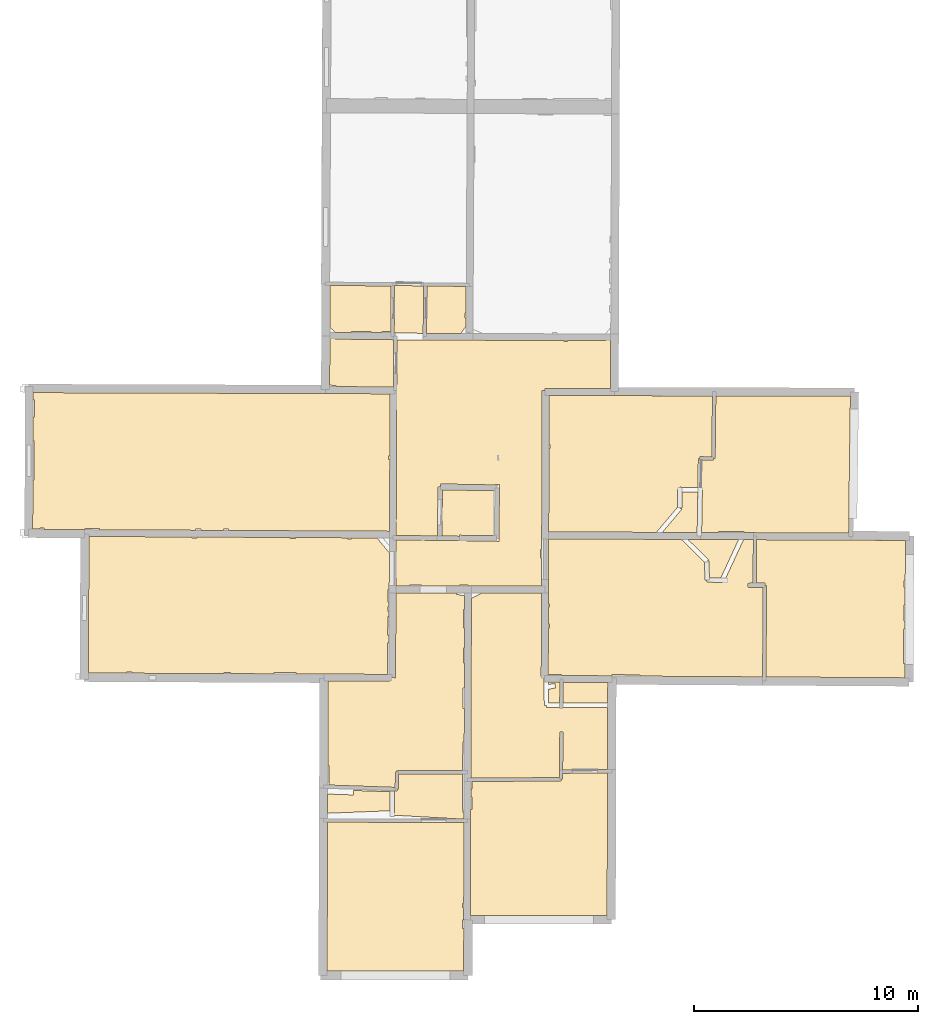
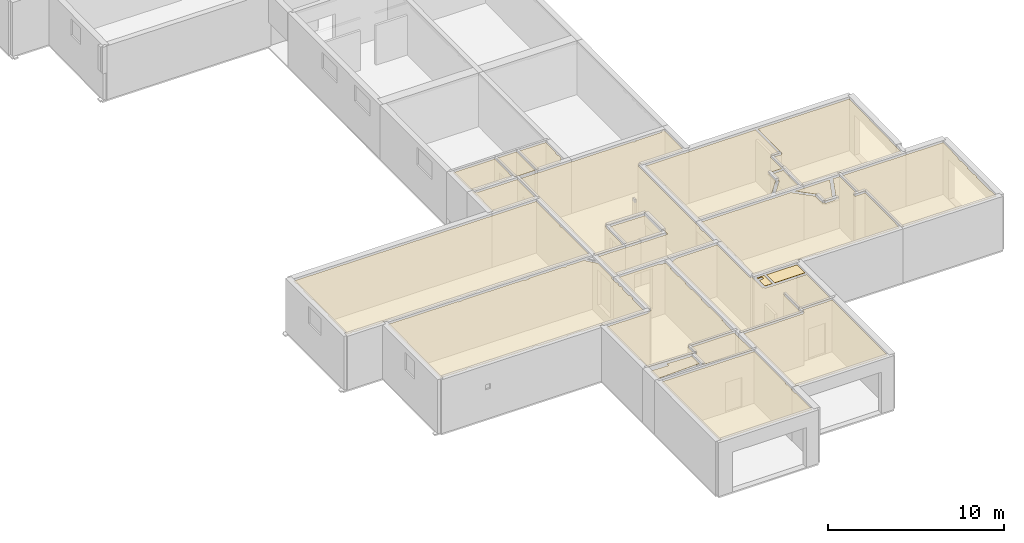
# One storey, part 8 of 12: 22 coverings.
"""IFC2X3 building model written with IfcOpenShell, lengths in metres."""

from ifc_helpers import new_model, entity, si_unit, converted_unit, derived_unit, direction, frame, origin, origin_with_axes, place, context, subcontext, project, spatial, polyline, outline, extrude, material, layer, layer_set, layer_usage, type_object, element, save


model = new_model("IFC2X3")

# Units and contexts
model_context = context("Model", 3, precision=1e-05, world=origin(), true_north=direction((0.0, 1.0)))
body_context = subcontext(model_context, "Body", "Model", "MODEL_VIEW")
ifc_project = project(units=[si_unit("LENGTHUNIT", "METRE"), si_unit("AREAUNIT", "SQUARE_METRE"), si_unit("VOLUMEUNIT", "CUBIC_METRE"), converted_unit("PLANEANGLEUNIT", "DEGREE", entity("IfcRatioMeasure", 0.0174532925199433), si_unit("PLANEANGLEUNIT", "RADIAN"), dimensions=[0, 0, 0, 0, 0, 0, 0]), si_unit("MASSUNIT", "GRAM", prefix="KILO"), derived_unit("MASSDENSITYUNIT", [(si_unit("MASSUNIT", "GRAM", prefix="KILO"), 1), (si_unit("LENGTHUNIT", "METRE"), -3)]), derived_unit("MOMENTOFINERTIAUNIT", [(si_unit("LENGTHUNIT", "METRE"), 4)]), si_unit("TIMEUNIT", "SECOND"), si_unit("FREQUENCYUNIT", "HERTZ"), si_unit("THERMODYNAMICTEMPERATUREUNIT", "DEGREE_CELSIUS"), derived_unit("THERMALTRANSMITTANCEUNIT", [(si_unit("MASSUNIT", "GRAM", prefix="KILO"), 1), (si_unit("THERMODYNAMICTEMPERATUREUNIT", "KELVIN"), -1), (si_unit("TIMEUNIT", "SECOND"), -3)]), derived_unit("VOLUMETRICFLOWRATEUNIT", [(si_unit("LENGTHUNIT", "METRE"), 3), (si_unit("TIMEUNIT", "SECOND"), -1)]), si_unit("ELECTRICCURRENTUNIT", "AMPERE"), si_unit("ELECTRICVOLTAGEUNIT", "VOLT"), si_unit("POWERUNIT", "WATT"), si_unit("FORCEUNIT", "NEWTON", prefix="KILO"), si_unit("ILLUMINANCEUNIT", "LUX"), si_unit("LUMINOUSFLUXUNIT", "LUMEN"), si_unit("LUMINOUSINTENSITYUNIT", "CANDELA"), derived_unit("USERDEFINED", [(si_unit("MASSUNIT", "GRAM", prefix="KILO"), -1), (si_unit("LENGTHUNIT", "METRE"), -2), (si_unit("TIMEUNIT", "SECOND"), 3), (si_unit("LUMINOUSFLUXUNIT", "LUMEN"), 1)]), derived_unit("LINEARVELOCITYUNIT", [(si_unit("LENGTHUNIT", "METRE"), 1), (si_unit("TIMEUNIT", "SECOND"), -1)]), si_unit("PRESSUREUNIT", "PASCAL"), derived_unit("USERDEFINED", [(si_unit("LENGTHUNIT", "METRE"), -2), (si_unit("MASSUNIT", "GRAM", prefix="KILO"), 1), (si_unit("TIMEUNIT", "SECOND"), -2)]), derived_unit("LINEARFORCEUNIT", [(si_unit("MASSUNIT", "GRAM", prefix="KILO"), 1), (si_unit("LENGTHUNIT", "METRE"), 1), (si_unit("TIMEUNIT", "SECOND"), -2), (si_unit("LENGTHUNIT", "METRE"), -1)]), derived_unit("PLANARFORCEUNIT", [(si_unit("MASSUNIT", "GRAM", prefix="KILO"), 1), (si_unit("LENGTHUNIT", "METRE"), 1), (si_unit("TIMEUNIT", "SECOND"), -2), (si_unit("LENGTHUNIT", "METRE"), -2)])], contexts=[model_context])

# Site, building, storey
placement = place(None, origin())
site = spatial("IfcSite", under=ifc_project, at=placement, CompositionType="ELEMENT")
building = spatial("IfcBuilding", under=site, at=placement, CompositionType="ELEMENT")
storey_placement = place(placement, frame((0.0, 0.0, -1.46125340461731)))
storey = spatial("IfcBuildingStorey", under=building, at=storey_placement, Name="Level 1", CompositionType="ELEMENT", Elevation=-1.46125340461731)

# Coverings
ifc_material = material(Name="Covering default")
ifc_layer_1 = layer(ifc_material, 0.02)
ifc_layer_set_1 = layer_set([ifc_layer_1], Name="Covering : 20mm")
ifc_layer_usage_1 = layer_usage(ifc_layer_set_1, "AXIS3", "POSITIVE", 0.0)
covering_type_1 = type_object("IfcCoveringType", Name="Covering : 20mm", PredefinedType="CEILING")
covering_1_placement = place(placement, frame((0.0, 0.0, 2.11485385894775)))
element("IfcCovering", 1, at=covering_1_placement, inside=storey, type_object=covering_type_1, material=ifc_layer_usage_1, Name="Covering : 20mm", ObjectType="Covering : 20mm", PredefinedType="CEILING", context=body_context, shape_type="SweptSolid", body=[
    extrude(outline(polyline([(-0.0963687896728516, 6.62952041625977), (5.98122024536133, 6.60954189300537), (5.97014427185059, 2.99506211280823), (5.91123962402344, 2.99501037597656), (5.9113883972168, 2.82501220703125), (5.96962356567383, 2.82506346702576), (5.96794891357422, 2.27837562561035), (6.10456275939941, 2.27795696258545), (5.9218692779541, 2.27779603004456), (5.92221450805664, 1.88502502441406), (5.97488975524902, 1.88507151603699), (5.96163558959961, -0.0119584202766418), (-0.121143341064453, -0.0165714919567108), (-0.0963687896728516, 6.62952041625977)])), origin_with_axes(), (0.0, 0.0, 1.0), 0.02),
])
ifc_layer_2 = layer(ifc_material, 0.02)
ifc_layer_set_2 = layer_set([ifc_layer_2], Name="Covering : 20mm")
ifc_layer_usage_2 = layer_usage(ifc_layer_set_2, "AXIS3", "POSITIVE", 0.0)
covering_type_2 = type_object("IfcCoveringType", Name="Covering : 20mm", PredefinedType="CEILING")
covering_2_placement = place(placement, frame((0.0, 0.0, 2.11485385894775)))
element("IfcCovering", 2, at=covering_2_placement, inside=storey, type_object=covering_type_2, material=ifc_layer_usage_2, Name="Covering : 20mm", ObjectType="Covering : 20mm", PredefinedType="CEILING", context=body_context, shape_type="SweptSolid", body=[
    extrude(outline(polyline([(6.28301620483398, 7.19533681869507), (6.33754920959473, 7.19538497924805), (6.33706665039062, 7.7453875541687), (6.28470230102539, 7.74534177780151), (6.28584098815918, 8.11738300323486), (6.33674049377441, 8.11539268493652), (6.34932899475098, 8.4371976852417), (10.309154510498, 8.46616649627686), (10.3086071014404, 8.54116344451904), (10.378604888916, 8.54075717926025), (10.3801307678223, 8.80403232574463), (12.3781356811523, 8.82392311096191), (12.3606109619141, 2.4650502204895), (6.26851463317871, 2.46296834945679), (6.28301620483398, 7.19533681869507)])), origin_with_axes(), (0.0, 0.0, 1.0), 0.02),
])
ifc_layer_3 = layer(ifc_material, 0.02)
ifc_layer_set_3 = layer_set([ifc_layer_3], Name="Covering : 20mm")
ifc_layer_usage_3 = layer_usage(ifc_layer_set_3, "AXIS3", "POSITIVE", 0.0)
covering_type_3 = type_object("IfcCoveringType", Name="Covering : 20mm", PredefinedType="CEILING")
covering_3_placement = place(placement, frame((0.0, 0.0, 2.11485385894775)))
element("IfcCovering", 3, at=covering_3_placement, inside=storey, type_object=covering_type_3, material=ifc_layer_usage_3, Name="Covering : 20mm", ObjectType="Covering : 20mm", PredefinedType="CEILING", context=body_context, shape_type="SweptSolid", body=[
    extrude(outline(polyline([(2.78989410400391, 6.93865871429443), (2.7858715057373, 7.03857851028442), (2.88587188720703, 7.03893566131592), (2.88233757019043, 8.02890682220459), (2.9877758026123, 8.02519226074219), (2.99041557312012, 8.10014343261719), (3.0654125213623, 8.09936714172363), (3.07246589660645, 8.7804651260376), (5.91583442687988, 8.77868938446045), (5.92767333984375, 7.05502700805664), (5.98258590698242, 7.05540418624878), (5.98167991638184, 6.75954103469849), (2.78989410400391, 6.93865871429443)])), origin_with_axes(), (0.0, 0.0, 1.0), 0.02),
])
ifc_layer_4 = layer(ifc_material, 0.02)
ifc_layer_set_4 = layer_set([ifc_layer_4], Name="Covering : 20mm")
ifc_layer_usage_4 = layer_usage(ifc_layer_set_4, "AXIS3", "POSITIVE", 0.0)
covering_type_4 = type_object("IfcCoveringType", Name="Covering : 20mm", PredefinedType="CEILING")
covering_4_placement = place(placement, frame((0.0, 0.0, 2.11485385894775)))
element("IfcCovering", 4, at=covering_4_placement, inside=storey, type_object=covering_type_4, material=ifc_layer_usage_4, Name="Covering : 20mm", ObjectType="Covering : 20mm", PredefinedType="CEILING", context=body_context, shape_type="SweptSolid", body=[
    extrude(outline(polyline([(-0.0916996002197266, 7.88211870193481), (1.05964374542236, 7.84087991714478), (1.06680297851562, 8.04075241088867), (2.68249702453613, 7.98376989364624), (2.6855297088623, 7.13461971282959), (-0.0949029922485352, 7.02269601821899), (-0.0916996002197266, 7.88211870193481)])), origin_with_axes(), (0.0, 0.0, 1.0), 0.02),
])
ifc_layer_5 = layer(ifc_material, 0.02)
ifc_layer_set_5 = layer_set([ifc_layer_5], Name="Covering : 20mm")
ifc_layer_usage_5 = layer_usage(ifc_layer_set_5, "AXIS3", "POSITIVE", 0.0)
covering_type_5 = type_object("IfcCoveringType", Name="Covering : 20mm", PredefinedType="CEILING")
covering_5_placement = place(placement, frame((0.0, 0.0, 2.11485385894775)))
element("IfcCovering", 5, at=covering_5_placement, inside=storey, type_object=covering_type_5, material=ifc_layer_usage_5, Name="Covering : 20mm", ObjectType="Covering : 20mm", PredefinedType="CEILING", context=body_context, shape_type="SweptSolid", body=[
    extrude(outline(polyline([(-0.0728960037231445, 12.9266767501831), (2.68170928955078, 12.9141788482666), (2.6823902130127, 13.0641679763794), (2.93192863464355, 13.0630531311035), (2.94876480102539, 16.8329925537109), (2.79961395263672, 16.8336582183838), (5.65909576416016, 16.8365707397461), (5.64912033081055, 16.7847843170166), (6.01218414306641, 16.7148475646973), (6.01031494140625, 16.1044960021973), (5.95971870422363, 16.1050605773926), (5.95044708251953, 15.2750511169434), (6.00777053833008, 15.2744112014771), (6.00507545471191, 14.3950977325439), (5.95122146606445, 14.3950500488281), (5.95181846618652, 13.7150497436523), (6.00299263000488, 13.7150945663452), (5.99959182739258, 12.605094909668), (5.94279289245605, 12.6050453186035), (5.94360160827637, 11.6850471496582), (5.99677276611328, 11.6850938796997), (5.99223327636719, 10.2041473388672), (5.93490219116211, 10.2050361633301), (5.91510200500488, 8.92868995666504), (2.9982852935791, 8.93051147460938), (2.99823760986328, 8.85550975799561), (2.92324256896973, 8.85628604888916), (2.91621589660645, 8.17780685424805), (-0.0334091186523438, 8.2817268371582), (-0.0341815948486328, 9.1597900390625), (-0.0869369506835938, 9.159743309021), (-0.0728960037231445, 12.9266767501831)])), origin_with_axes(), (0.0, 0.0, 1.0), 0.02),
])
ifc_layer_6 = layer(ifc_material, 0.02)
ifc_layer_set_6 = layer_set([ifc_layer_6], Name="Covering : 20mm")
ifc_layer_usage_6 = layer_usage(ifc_layer_set_6, "AXIS3", "POSITIVE", 0.0)
covering_type_6 = type_object("IfcCoveringType", Name="Covering : 20mm", PredefinedType="CEILING")
covering_6_placement = place(placement, frame((0.0, 0.0, 2.11485385894775)))
element("IfcCovering", 6, at=covering_6_placement, inside=storey, type_object=covering_type_6, material=ifc_layer_usage_6, Name="Covering : 20mm", ObjectType="Covering : 20mm", PredefinedType="CEILING", context=body_context, shape_type="SweptSolid", body=[
    extrude(outline(polyline([(6.31185531616211, 16.6066589355469), (6.7729434967041, 16.8377056121826), (9.43655014038086, 16.8404159545898), (9.42335510253906, 13.1187858581543), (9.55743026733398, 13.1183109283447), (9.55891799926758, 11.8368263244629), (9.65891647338867, 11.8369417190552), (9.65739059448242, 11.7369527816772), (10.1935176849365, 11.7287759780884), (12.3861465454102, 11.7307024002075), (12.3785495758057, 8.9739351272583), (10.3809986114502, 8.9540491104126), (10.3908195495605, 10.6484823226929), (10.2508201599121, 10.6492938995361), (10.2390384674072, 8.61565780639648), (6.28727912902832, 8.58674716949463), (6.31185531616211, 16.6066589355469)])), origin_with_axes(), (0.0, 0.0, 1.0), 0.02),
])
ifc_layer_7 = layer(ifc_material, 0.02)
ifc_layer_set_7 = layer_set([ifc_layer_7], Name="Covering : 20mm")
ifc_layer_usage_7 = layer_usage(ifc_layer_set_7, "AXIS3", "POSITIVE", 0.0)
covering_type_7 = type_object("IfcCoveringType", Name="Covering : 20mm", PredefinedType="CEILING")
covering_7_placement = place(placement, frame((0.0, 0.0, 2.11485385894775)))
element("IfcCovering", 7, at=covering_7_placement, inside=storey, type_object=covering_type_7, material=ifc_layer_usage_7, Name="Covering : 20mm", ObjectType="Covering : 20mm", PredefinedType="CEILING", context=body_context, shape_type="SweptSolid", body=[
    extrude(outline(polyline([(9.75808334350586, 12.5551595687866), (10.068567276001, 12.6118936538696), (10.0326156616211, 12.8086357116699), (9.75784873962402, 12.7584276199341), (9.75772094726562, 12.8677806854248), (10.2539558410645, 12.8643016815186), (10.2475738525391, 11.9279747009277), (9.75880241394043, 11.9354295730591), (9.75808334350586, 12.5551595687866)])), origin_with_axes(), (0.0, 0.0, 1.0), 0.02),
])
ifc_layer_8 = layer(ifc_material, 0.02)
ifc_layer_set_8 = layer_set([ifc_layer_8], Name="Covering : 20mm")
ifc_layer_usage_8 = layer_usage(ifc_layer_set_8, "AXIS3", "POSITIVE", 0.0)
covering_type_8 = type_object("IfcCoveringType", Name="Covering : 20mm", PredefinedType="CEILING")
covering_8_placement = place(placement, frame((0.0, 0.0, 2.11485385894775)))
element("IfcCovering", 8, at=covering_8_placement, inside=storey, type_object=covering_type_8, material=ifc_layer_usage_8, Name="Covering : 20mm", ObjectType="Covering : 20mm", PredefinedType="CEILING", context=body_context, shape_type="SweptSolid", body=[
    extrude(outline(polyline([(10.4039535522461, 12.8632507324219), (12.3892307281494, 12.8493328094482), (12.3866996765137, 11.9307022094727), (10.3975849151611, 11.928955078125), (10.4039535522461, 12.8632507324219)])), origin_with_axes(), (0.0, 0.0, 1.0), 0.02),
])
ifc_layer_9 = layer(ifc_material, 0.02)
ifc_layer_set_9 = layer_set([ifc_layer_9], Name="Covering : 20mm")
ifc_layer_usage_9 = layer_usage(ifc_layer_set_9, "AXIS3", "POSITIVE", 0.0)
covering_type_9 = type_object("IfcCoveringType", Name="Covering : 20mm", PredefinedType="CEILING")
covering_9_placement = place(placement, frame((0.0, 0.0, 2.11485385894775)))
element("IfcCovering", 9, at=covering_9_placement, inside=storey, type_object=covering_type_9, material=ifc_layer_usage_9, Name="Covering : 20mm", ObjectType="Covering : 20mm", PredefinedType="CEILING", context=body_context, shape_type="SweptSolid", body=[
    extrude(outline(polyline([(19.028205871582, 19.2152690887451), (25.6530685424805, 19.1850509643555), (25.6458587646484, 17.3923568725586), (25.5885963439941, 17.3923072814941), (25.5888671875, 17.0823097229004), (25.6446113586426, 17.0823593139648), (25.641471862793, 16.3016109466553), (25.5895538330078, 16.3023071289062), (25.5801696777344, 15.6023044586182), (25.6386566162109, 15.6015205383301), (25.6372909545898, 15.2619924545288), (25.5804672241211, 15.2623043060303), (25.5718460083008, 13.6922950744629), (25.6309776306152, 13.691969871521), (25.6284446716309, 13.0618162155151), (19.4390869140625, 13.1009616851807), (19.4682693481445, 17.1844863891602), (19.3932723999023, 17.185022354126), (19.3917999267578, 17.2850112915039), (19.0125503540039, 17.2794246673584), (19.028205871582, 19.2152690887451)])), origin_with_axes(), (0.0, 0.0, 1.0), 0.02),
])
ifc_layer_10 = layer(ifc_material, 0.02)
ifc_layer_set_10 = layer_set([ifc_layer_10], Name="Covering : 20mm")
ifc_layer_usage_10 = layer_usage(ifc_layer_set_10, "AXIS3", "POSITIVE", 0.0)
covering_type_10 = type_object("IfcCoveringType", Name="Covering : 20mm", PredefinedType="CEILING")
covering_10_placement = place(placement, frame((0.0, 0.0, 2.11485385894775)))
element("IfcCovering", 10, at=covering_10_placement, inside=storey, type_object=covering_type_10, material=ifc_layer_usage_10, Name="Covering : 20mm", ObjectType="Covering : 20mm", PredefinedType="CEILING", context=body_context, shape_type="SweptSolid", body=[
    extrude(outline(polyline([(9.74101448059082, 15.2783823013306), (9.80044555664062, 15.278434753418), (9.80029678344727, 15.4484367370605), (9.74161720275879, 15.4483852386475), (9.74431228637695, 16.2083854675293), (9.79962921142578, 16.2084331512451), (9.79949760437012, 16.358434677124), (9.74484443664551, 16.3583869934082), (9.75510406494141, 19.2528305053711), (15.6705379486084, 19.2288703918457), (16.708797454834, 18.2138023376465), (16.7142276763916, 17.4197959899902), (16.8142261505127, 17.4204807281494), (16.8138065338135, 17.3204765319824), (17.4945106506348, 17.3176193237305), (17.494930267334, 17.4176177978516), (17.5856285095215, 17.3755035400391), (18.4410095214844, 19.2176475524902), (18.8782081604004, 19.2158756256104), (18.8625259399414, 17.277214050293), (18.6476058959961, 17.2740478515625), (18.6505508422852, 17.0740699768066), (19.3175506591797, 17.0838966369629), (19.2890930175781, 13.1019096374512), (13.8218650817871, 13.1364879608154), (13.8222808837891, 13.1919708251953), (12.5806770324707, 13.2013082504272), (12.5802764892578, 13.1480007171631), (10.3306541442871, 13.1637716293335), (10.3306045532227, 13.2189025878906), (9.73371124267578, 13.2183771133423), (9.74101448059082, 15.2783823013306)])), origin_with_axes(), (0.0, 0.0, 1.0), 0.02),
])
ifc_layer_11 = layer(ifc_material, 0.02)
ifc_layer_set_11 = layer_set([ifc_layer_11], Name="Covering : 20mm")
ifc_layer_usage_11 = layer_usage(ifc_layer_set_11, "AXIS3", "POSITIVE", 0.0)
covering_type_11 = type_object("IfcCoveringType", Name="Covering : 20mm", PredefinedType="CEILING")
covering_11_placement = place(placement, frame((0.0, 0.0, 2.11485385894775)))
element("IfcCovering", 11, at=covering_11_placement, inside=storey, type_object=covering_type_11, material=ifc_layer_usage_11, Name="Covering : 20mm", ObjectType="Covering : 20mm", PredefinedType="CEILING", context=body_context, shape_type="SweptSolid", body=[
    extrude(outline(polyline([(-10.7309856414795, 19.3598442077637), (-6.1331262588501, 19.3364505767822), (-6.13308095932007, 19.2844352722168), (-5.92307996749878, 19.2846183776855), (-5.92312431335449, 19.3353824615479), (-1.78310585021973, 19.3143196105957), (-1.78305625915527, 19.2582588195801), (-1.52305603027344, 19.258487701416), (-1.52310371398926, 19.3129959106445), (0.800071716308594, 19.301176071167), (0.796952247619629, 19.250524520874), (0.956960678100586, 19.240665435791), (0.960638999938965, 19.3003597259521), (2.10285091400146, 19.294548034668), (2.65679168701172, 18.6310024261475), (2.64945602416992, 16.9885120391846), (2.58894157409668, 16.9884586334229), (2.58942222595215, 16.4420986175537), (2.64701652526855, 16.4421482086182), (2.64612197875977, 16.2421474456787), (2.58959770202637, 16.2420978546143), (2.58979988098145, 16.0120983123779), (2.64509582519531, 16.0121459960938), (2.64406585693359, 15.7814846038818), (2.59000205993652, 15.782096862793), (2.58072280883789, 14.9620895385742), (2.64040374755859, 14.9614143371582), (2.6387996673584, 14.6021432876587), (2.58103942871094, 14.6020927429199), (2.5822582244873, 13.2146339416504), (-0.261617660522461, 13.2275371551514), (-0.261617660522461, 13.2275352478027), (-1.5077600479126, 13.2331886291504), (-1.50780868530273, 13.2884922027588), (-2.47780990600586, 13.2876396179199), (-2.4777660369873, 13.2375888824463), (-4.42777347564697, 13.2464351654053), (-4.42782592773438, 13.3059310913086), (-4.71782684326172, 13.3056755065918), (-4.71777534484863, 13.2477512359619), (-8.80779075622559, 13.2663059234619), (-8.80784034729004, 13.3220825195312), (-9.05784034729004, 13.3218631744385), (-9.05779266357422, 13.2674407958984), (-10.7573442459106, 13.2751502990723), (-10.7309856414795, 19.3598442077637)])), origin_with_axes(), (0.0, 0.0, 1.0), 0.02),
])
ifc_layer_12 = layer(ifc_material, 0.02)
ifc_layer_set_12 = layer_set([ifc_layer_12], Name="Covering : 20mm")
ifc_layer_usage_12 = layer_usage(ifc_layer_set_12, "AXIS3", "POSITIVE", 0.0)
covering_type_12 = type_object("IfcCoveringType", Name="Covering : 20mm", PredefinedType="CEILING")
covering_12_placement = place(placement, frame((0.0, 0.0, 2.11485385894775)))
element("IfcCovering", 12, at=covering_12_placement, inside=storey, type_object=covering_type_12, material=ifc_layer_usage_12, Name="Covering : 20mm", ObjectType="Covering : 20mm", PredefinedType="CEILING", context=body_context, shape_type="SweptSolid", body=[
    extrude(outline(polyline([(2.95936393737793, 19.2061996459961), (7.33490180969238, 19.154109954834), (7.33482933044434, 19.1478366851807), (7.53481674194336, 19.1455192565918), (7.56401443481445, 21.6653499603271), (7.36402893066406, 21.667667388916), (7.3639030456543, 21.6567306518555), (4.93128204345703, 21.7003917694092), (4.9289493560791, 21.5704116821289), (4.82896423339844, 21.572172164917), (4.79036331176758, 19.3816394805908), (2.96025657653809, 19.4062061309814), (2.99254035949707, 28.1198177337646), (10.4391860961914, 28.0905094146729), (10.4392318725586, 28.0389995574951), (10.5892333984375, 28.0391311645508), (10.5891895294189, 28.0899181365967), (12.3056983947754, 28.0831623077393), (12.3062896728516, 28.2331619262695), (12.3857765197754, 28.1724872589111), (12.5202865600586, 28.3487014770508), (12.5115242004395, 25.9438610076904), (9.62465667724609, 25.950345993042), (9.62480545043945, 25.9619369506836), (9.5849609375, 25.9624462127686), (9.58333396911621, 25.8349571228027), (9.58339500427246, 25.8620910644531), (9.46852874755859, 25.8624973297119), (9.44345283508301, 18.7881202697754), (9.38736152648926, 18.7880706787109), (9.3876953125, 18.408073425293), (9.44210624694824, 18.4081211090088), (9.43764877319336, 17.1504173278809), (6.16334533691406, 17.1470832824707), (6.16329383850098, 17.2052383422852), (5.77875137329102, 17.2049007415771), (5.7788028717041, 17.146692276001), (4.07880401611328, 17.1449604034424), (4.0787525177002, 17.2034072875977), (3.55875205993652, 17.2029495239258), (3.55880355834961, 17.1444320678711), (2.95015335083008, 17.1438121795654), (2.95936393737793, 19.2061996459961)])), origin_with_axes(), (0.0, 0.0, 1.0), 0.02),
])
ifc_layer_13 = layer(ifc_material, 0.02)
ifc_layer_set_13 = layer_set([ifc_layer_13], Name="Covering : 20mm")
ifc_layer_usage_13 = layer_usage(ifc_layer_set_13, "AXIS3", "POSITIVE", 0.0)
covering_type_13 = type_object("IfcCoveringType", Name="Covering : 20mm", PredefinedType="CEILING")
covering_13_placement = place(placement, frame((0.0, 0.0, 2.11485385894775)))
element("IfcCovering", 13, at=covering_13_placement, inside=storey, type_object=covering_type_13, material=ifc_layer_usage_13, Name="Covering : 20mm", ObjectType="Covering : 20mm", PredefinedType="CEILING", context=body_context, shape_type="SweptSolid", body=[
    extrude(outline(polyline([(16.8784236907959, 18.3276653289795), (16.8085193634033, 18.2561645507812), (16.9085083007812, 18.2568473815918), (16.9135456085205, 17.5200595855713), (17.4312324523926, 17.5178871154785), (18.2209129333496, 19.2185382843018), (16.5223369598389, 19.2254199981689), (15.957820892334, 19.2277069091797), (16.8784236907959, 18.3276653289795)])), origin_with_axes(), (0.0, 0.0, 1.0), 0.02),
])
ifc_layer_14 = layer(ifc_material, 0.02)
ifc_layer_set_14 = layer_set([ifc_layer_14], Name="Covering : 20mm")
ifc_layer_usage_14 = layer_usage(ifc_layer_set_14, "AXIS3", "POSITIVE", 0.0)
covering_type_14 = type_object("IfcCoveringType", Name="Covering : 20mm", PredefinedType="CEILING")
covering_14_placement = place(placement, frame((0.0, 0.0, 2.11485385894775)))
element("IfcCovering", 14, at=covering_14_placement, inside=storey, type_object=covering_type_14, material=ifc_layer_usage_14, Name="Covering : 20mm", ObjectType="Covering : 20mm", PredefinedType="CEILING", context=body_context, shape_type="SweptSolid", body=[
    extrude(outline(polyline([(5.02664375305176, 21.4386386871338), (7.36088943481445, 21.3967418670654), (7.33779907226562, 19.4040946960449), (5.7849063873291, 19.4145030975342), (5.78459739685059, 19.368293762207), (4.99034881591797, 19.3789558410645), (5.02664375305176, 21.4386386871338)])), origin_with_axes(), (0.0, 0.0, 1.0), 0.02),
])
ifc_layer_15 = layer(ifc_material, 0.02)
ifc_layer_set_15 = layer_set([ifc_layer_15], Name="Covering : 20mm")
ifc_layer_usage_15 = layer_usage(ifc_layer_set_15, "AXIS3", "POSITIVE", 0.0)
covering_type_15 = type_object("IfcCoveringType", Name="Covering : 20mm", PredefinedType="CEILING")
covering_15_placement = place(placement, frame((0.0, 0.0, 2.11485385894775)))
element("IfcCovering", 15, at=covering_15_placement, inside=storey, type_object=covering_type_15, material=ifc_layer_usage_15, Name="Covering : 20mm", ObjectType="Covering : 20mm", PredefinedType="CEILING", context=body_context, shape_type="SweptSolid", body=[
    extrude(outline(polyline([(16.5744228363037, 22.7650718688965), (17.0981712341309, 22.7574157714844), (17.0992565155029, 22.8316516876221), (17.1742534637451, 22.8307952880859), (17.2061233520508, 25.6252899169922), (23.2026176452637, 25.6111373901367), (23.1283569335938, 20.1548366546631), (23.135856628418, 20.1547336578369), (23.1276550292969, 19.5086669921875), (18.4553413391113, 19.5275917053223), (18.4552917480469, 19.5860424041748), (17.3266639709473, 19.5850505828857), (17.3267097473145, 19.5321636199951), (16.5722122192383, 19.5352210998535), (16.6065063476562, 21.4404411315918), (16.5543022155762, 21.4413814544678), (16.5744228363037, 22.7650718688965)])), origin_with_axes(), (0.0, 0.0, 1.0), 0.02),
])
ifc_layer_16 = layer(ifc_material, 0.02)
ifc_layer_set_16 = layer_set([ifc_layer_16], Name="Covering : 20mm")
ifc_layer_usage_16 = layer_usage(ifc_layer_set_16, "AXIS3", "POSITIVE", 0.0)
covering_type_16 = type_object("IfcCoveringType", Name="Covering : 20mm", PredefinedType="CEILING")
covering_16_placement = place(placement, frame((0.0, 0.0, 2.11485385894775)))
element("IfcCovering", 16, at=covering_16_placement, inside=storey, type_object=covering_type_16, material=ifc_layer_usage_16, Name="Covering : 20mm", ObjectType="Covering : 20mm", PredefinedType="CEILING", context=body_context, shape_type="SweptSolid", body=[
    extrude(outline(polyline([(14.8174839019775, 19.5423278808594), (15.6812496185303, 20.5649662017822), (15.6048526763916, 20.6294937133789), (15.70485496521, 20.6298522949219), (15.7022647857666, 21.3525466918945), (16.4027976989746, 21.3435649871826), (16.3923072814941, 20.6534366607666), (16.3923072814941, 20.6534366607666), (16.3923072814941, 20.6534366607666), (16.3923072814941, 20.6534366607666), (16.3923072814941, 20.6534366607666), (16.3923072814941, 20.6534366607666), (16.3923072814941, 20.6534366607666), (16.3923072814941, 20.6534366607666), (16.3923072814941, 20.6534366607666), (16.3721942901611, 19.5360298156738), (14.8174839019775, 19.5423278808594)])), origin_with_axes(), (0.0, 0.0, 1.0), 0.02),
])
ifc_layer_17 = layer(ifc_material, 0.02)
ifc_layer_set_17 = layer_set([ifc_layer_17], Name="Covering : 20mm")
ifc_layer_usage_17 = layer_usage(ifc_layer_set_17, "AXIS3", "POSITIVE", 0.0)
covering_type_17 = type_object("IfcCoveringType", Name="Covering : 20mm", PredefinedType="CEILING")
covering_17_placement = place(placement, frame((0.0, 0.0, 2.11485385894775)))
element("IfcCovering", 17, at=covering_17_placement, inside=storey, type_object=covering_type_17, material=ifc_layer_usage_17, Name="Covering : 20mm", ObjectType="Covering : 20mm", PredefinedType="CEILING", context=body_context, shape_type="SweptSolid", body=[
    extrude(outline(polyline([(9.76940727233887, 23.2884082794189), (9.82340812683105, 23.2884559631348), (9.82324981689453, 23.4684562683105), (9.77004623413086, 23.4684104919434), (9.77774429321289, 25.6400012969971), (17.0561180114746, 25.6256446838379), (17.0251121520996, 22.9069900512695), (16.5016460418701, 22.9146423339844), (16.5005588531494, 22.8404006958008), (16.4255676269531, 22.8415412902832), (16.4058380126953, 21.5435409545898), (15.6031818389893, 21.5538330078125), (15.6018981933594, 21.4538402557373), (15.5019016265869, 21.4534816741943), (15.5047245025635, 20.6659202575684), (14.556583404541, 19.543384552002), (9.75620269775391, 19.5628280639648), (9.76940727233887, 23.2884082794189)])), origin_with_axes(), (0.0, 0.0, 1.0), 0.02),
])
ifc_layer_18 = layer(ifc_material, 0.02)
ifc_layer_set_18 = layer_set([ifc_layer_18], Name="Covering : 20mm")
ifc_layer_usage_18 = layer_usage(ifc_layer_set_18, "AXIS3", "POSITIVE", 0.0)
covering_type_18 = type_object("IfcCoveringType", Name="Covering : 20mm", PredefinedType="CEILING")
covering_18_placement = place(placement, frame((0.0, 0.0, 2.11485385894775)))
element("IfcCovering", 18, at=covering_18_placement, inside=storey, type_object=covering_type_18, material=ifc_layer_usage_18, Name="Covering : 20mm", ObjectType="Covering : 20mm", PredefinedType="CEILING", context=body_context, shape_type="SweptSolid", body=[
    extrude(outline(polyline([(-13.2324333190918, 21.8681964874268), (-13.1753520965576, 21.8682460784912), (-13.1768989562988, 23.6282444000244), (-13.2273273468018, 23.6282005310059), (-13.2242527008057, 24.6882057189941), (-13.1678333282471, 24.6882553100586), (-13.1684913635254, 25.43825340271), (-13.2220764160156, 25.4382057189941), (-13.2211170196533, 25.7690734863281), (2.68843841552734, 25.7171974182129), (2.67604446411133, 22.942174911499), (2.62370872497559, 22.9421291351318), (2.62384796142578, 22.7821292877197), (2.67533111572266, 22.7821750640869), (2.66108322143555, 19.5917110443115), (-4.50337982177734, 19.6281623840332), (-4.50343132019043, 19.6858654022217), (-4.74343109130859, 19.6856536865234), (-4.74338150024414, 19.6293830871582), (-5.7454833984375, 19.6344814300537), (-5.74343109130859, 19.6847743988037), (-5.9834418296814, 19.6945667266846), (-5.98584318161011, 19.635705947876), (-10.2545232772827, 19.6574230194092), (-10.2534580230713, 19.7108135223389), (-10.9178466796875, 19.7240695953369), (-10.918909072876, 19.670804977417), (-12.7334318161011, 19.6814060211182), (-12.7334823608398, 19.7386341094971), (-12.9134826660156, 19.7384757995605), (-12.9134330749512, 19.6824569702148), (-13.23876953125, 19.6843566894531), (-13.2324333190918, 21.8681964874268)])), origin_with_axes(), (0.0, 0.0, 1.0), 0.02),
])
ifc_layer_19 = layer(ifc_material, 0.02)
ifc_layer_set_19 = layer_set([ifc_layer_19], Name="Covering : 20mm")
ifc_layer_usage_19 = layer_usage(ifc_layer_set_19, "AXIS3", "POSITIVE", 0.0)
covering_type_19 = type_object("IfcCoveringType", Name="Covering : 20mm", PredefinedType="CEILING")
covering_19_placement = place(placement, frame((0.0, 0.0, 2.11485385894775)))
element("IfcCovering", 19, at=covering_19_placement, inside=storey, type_object=covering_type_19, material=ifc_layer_usage_19, Name="Covering : 20mm", ObjectType="Covering : 20mm", PredefinedType="CEILING", context=body_context, shape_type="SweptSolid", body=[
    extrude(outline(polyline([(0.0112943649291992, 28.3967189788818), (0.160648345947266, 28.2340755462646), (0.234308242797852, 28.3017158508301), (0.233722686767578, 28.1517124176025), (2.79470825195312, 28.1417179107666), (2.79462432861328, 28.1205959320068), (2.8425407409668, 28.1204071044922), (2.83658218383789, 26.0267143249512), (0.268489837646484, 26.0350894927979), (0.270940780639648, 26.0900650024414), (-0.00863456726074219, 26.1025276184082), (0.0112943649291992, 28.3967189788818)])), origin_with_axes(), (0.0, 0.0, 1.0), 0.02),
])
ifc_layer_20 = layer(ifc_material, 0.02)
ifc_layer_set_20 = layer_set([ifc_layer_20], Name="Covering : 20mm")
ifc_layer_usage_20 = layer_usage(ifc_layer_set_20, "AXIS3", "POSITIVE", 0.0)
covering_type_20 = type_object("IfcCoveringType", Name="Covering : 20mm", PredefinedType="CEILING")
covering_20_placement = place(placement, frame((0.0, 0.0, 2.11485385894775)))
element("IfcCovering", 20, at=covering_20_placement, inside=storey, type_object=covering_type_20, material=ifc_layer_usage_20, Name="Covering : 20mm", ObjectType="Covering : 20mm", PredefinedType="CEILING", context=body_context, shape_type="SweptSolid", body=[
    extrude(outline(polyline([(4.32685089111328, 30.5254764556885), (6.08168411254883, 30.504093170166), (6.07551383972168, 29.3251647949219), (6.01810073852539, 29.3251152038574), (6.01830291748047, 29.0951156616211), (6.07430839538574, 29.0951652526855), (6.07241821289062, 28.733793258667), (5.85032081604004, 28.4085712432861), (4.31379890441895, 28.4146194458008), (4.32685089111328, 30.5254764556885)])), origin_with_axes(), (0.0, 0.0, 1.0), 0.02),
])
ifc_layer_21 = layer(ifc_material, 0.02)
ifc_layer_set_21 = layer_set([ifc_layer_21], Name="Covering : 20mm")
ifc_layer_usage_21 = layer_usage(ifc_layer_set_21, "AXIS3", "POSITIVE", 0.0)
covering_type_21 = type_object("IfcCoveringType", Name="Covering : 20mm", PredefinedType="CEILING")
covering_21_placement = place(placement, frame((0.0, 0.0, 2.11485385894775)))
element("IfcCovering", 21, at=covering_21_placement, inside=storey, type_object=covering_type_21, material=ifc_layer_usage_21, Name="Covering : 20mm", ObjectType="Covering : 20mm", PredefinedType="CEILING", context=body_context, shape_type="SweptSolid", body=[
    extrude(outline(polyline([(2.88688850402832, 30.5430221557617), (4.17685890197754, 30.5273036956787), (4.16379928588867, 28.4152088165283), (2.91852951049805, 28.4201107025146), (2.91861152648926, 28.4412364959717), (2.87147331237793, 28.4414196014404), (2.88688850402832, 30.5430221557617)])), origin_with_axes(), (0.0, 0.0, 1.0), 0.02),
])
ifc_layer_22 = layer(ifc_material, 0.02)
ifc_layer_set_22 = layer_set([ifc_layer_22], Name="Covering : 20mm")
ifc_layer_usage_22 = layer_usage(ifc_layer_set_22, "AXIS3", "POSITIVE", 0.0)
covering_type_22 = type_object("IfcCoveringType", Name="Covering : 20mm", PredefinedType="CEILING")
covering_22_placement = place(placement, frame((0.0, 0.0, 2.11485385894775)))
element("IfcCovering", 22, at=covering_22_placement, inside=storey, type_object=covering_type_22, material=ifc_layer_usage_22, Name="Covering : 20mm", ObjectType="Covering : 20mm", PredefinedType="CEILING", context=body_context, shape_type="SweptSolid", body=[
    extrude(outline(polyline([(0.232321739196777, 28.4517192840576), (0.958869934082031, 28.4488849639893), (0.958824157714844, 28.5006694793701), (1.82882404327393, 28.5014343261719), (1.82887268066406, 28.4454898834229), (2.31887435913086, 28.4435768127441), (2.31882476806641, 28.5018653869629), (2.7219123840332, 28.50221824646), (2.73675918579102, 30.5258445739746), (0.0143299102783203, 30.5429592132568), (0.0138387680053711, 28.6896438598633), (0.232321739196777, 28.4517192840576)])), origin_with_axes(), (0.0, 0.0, 1.0), 0.02),
])

save(model, "model.ifc")
